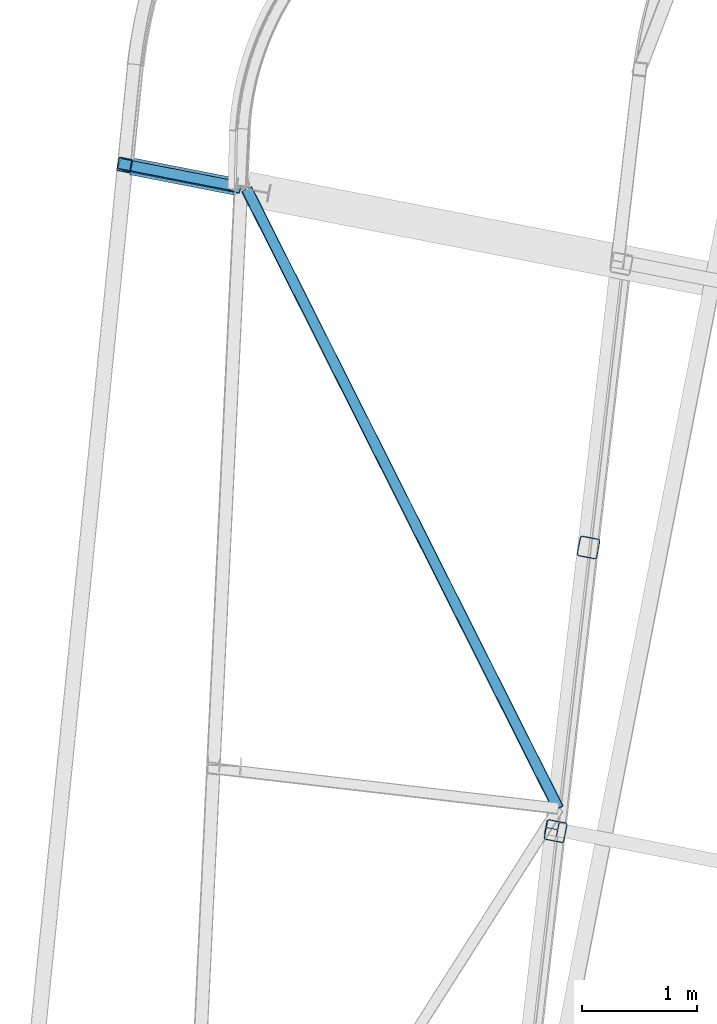
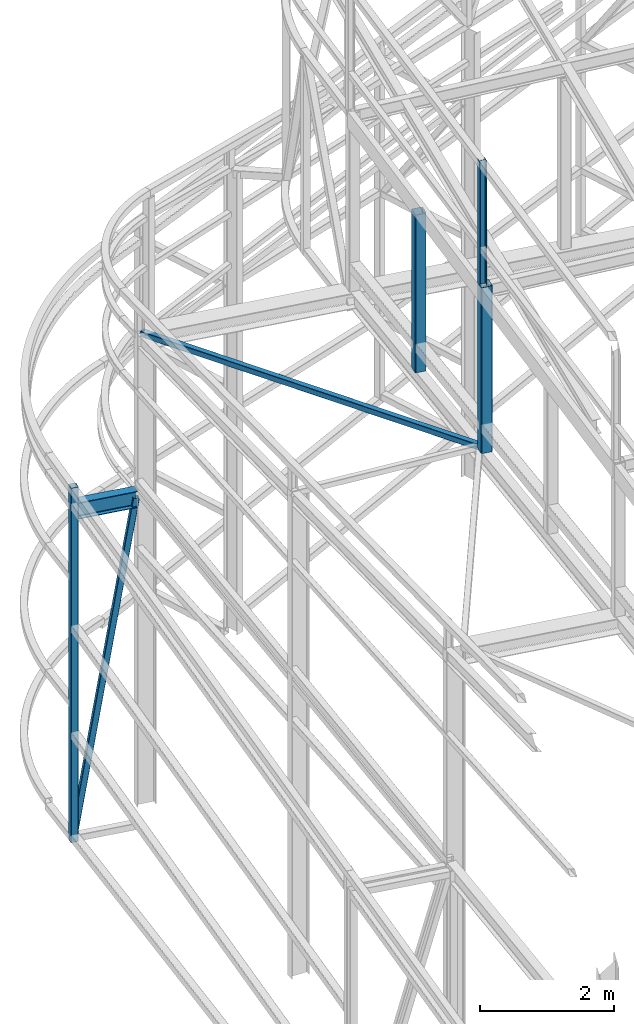
# One storey, part 76 of 215: 6 beams, 1 member, 7 elements without a shape of their own.
"""IFC2X3 building model written with IfcOpenShell, lengths in millimetres."""

from ifc_helpers import new_model, si_unit, frame, origin_with_axes, origin_2d_with_axis, place, context, subcontext, project, spatial, hollow_rectangle, i_section, extrude, clip, halfspace, material, type_object, element, aggregate, save


model = new_model("IFC2X3")

# Units and contexts
model_context = context("Model", 3, precision=1e-05, world=origin_with_axes())
body_context = subcontext(model_context, "Body", "Model", "MODEL_VIEW")
ifc_project = project(units=[si_unit("LENGTHUNIT", "METRE", prefix="MILLI"), si_unit("AREAUNIT", "SQUARE_METRE"), si_unit("VOLUMEUNIT", "CUBIC_METRE"), si_unit("MASSUNIT", "GRAM", prefix="KILO"), si_unit("TIMEUNIT", "SECOND"), si_unit("PLANEANGLEUNIT", "RADIAN"), si_unit("SOLIDANGLEUNIT", "STERADIAN"), si_unit("THERMODYNAMICTEMPERATUREUNIT", "DEGREE_CELSIUS"), si_unit("LUMINOUSINTENSITYUNIT", "LUMEN")], contexts=[model_context])

# Site, building, storey
site_placement = place(None, origin_with_axes())
site = spatial("IfcSite", under=ifc_project, at=site_placement, CompositionType="ELEMENT")
building_placement = place(site_placement, origin_with_axes())
building = spatial("IfcBuilding", under=site, at=building_placement, Name="Undefined", CompositionType="ELEMENT")
storey_placement = place(building_placement, origin_with_axes())
storey = spatial("IfcBuildingStorey", under=building, at=storey_placement, Name="Undefined", CompositionType="ELEMENT", Elevation=0.0)

# Assembly, beam
assembly_1_placement = place(storey_placement, origin_with_axes())
assembly_1 = element("IfcElementAssembly", 1, at=assembly_1_placement, inside=storey, Name="Steel Assembly", AssemblyPlace="NOTDEFINED", PredefinedType="RIGID_FRAME")
ifc_material = material(Name="STEEL/S275JR")
beam_type_1 = type_object("IfcBeamType", PredefinedType="NOTDEFINED")
beam_1_placement = place(assembly_1_placement, frame((38028.1385073162, 54568.5828169982, 6061.86710994504), z_axis=(-0.981474011903068, 0.191595312981076, 1.60599999965198e-06), x_axis=(-1.60500000047455e-06, 1.60999999464282e-07, -0.999999999998699)))
beam_1 = element("IfcBeam", 2, at=beam_1_placement, type_object=beam_type_1, material=ifc_material, Name="MONTANT", context=body_context, shape_type="SweptSolid", body=[
    extrude(hollow_rectangle(XDim=120.0, YDim=120.0, WallThickness=5.0, InnerFilletRadius=5.0, OuterFilletRadius=10.0, at=origin_2d_with_axis()), frame((6481.47571329646, -1.71563233624708e-19, -3.63798017959758e-12), z_axis=(-1.0, 0.0, 0.0), x_axis=(-6.93889390390723e-18, -1.0, -3.46944695195361e-18)), (0.0, 0.0, 1.0), 6481.5),
])
aggregate(assembly_1, [beam_1])

assembly_2_placement = place(storey_placement, origin_with_axes())
assembly_2 = element("IfcElementAssembly", 3, at=assembly_2_placement, inside=storey, Name="Steel Assembly", AssemblyPlace="NOTDEFINED", PredefinedType="RIGID_FRAME")
beam_type_2 = type_object("IfcBeamType", PredefinedType="NOTDEFINED")
beam_2_placement = place(assembly_2_placement, frame((39093.5616252917, 54357.4246603521, 8612.24870267854), z_axis=(0.893492208764054, 0.448243081881631, -0.0273827029927682), x_axis=(0.449041838079308, -0.892537652157635, 0.041688933007363)))
beam_2 = element("IfcBeam", 4, at=beam_2_placement, type_object=beam_type_2, material=ifc_material, context=body_context, shape_type="SweptSolid", body=[
    extrude(hollow_rectangle(XDim=100.0, YDim=100.0, WallThickness=5.0, InnerFilletRadius=5.0, OuterFilletRadius=10.0, at=origin_2d_with_axis()), frame((6055.13711101607, -1.81898940354586e-12, -1.15543873464118e-13), z_axis=(-1.0, 0.0, 0.0), x_axis=(-6.93889390390723e-18, -1.0, -3.46944695195361e-18)), (0.0, 0.0, 1.0), 6055.1),
])
aggregate(assembly_2, [beam_2])

# Assembly, member
assembly_3_placement = place(storey_placement, origin_with_axes())
assembly_3 = element("IfcElementAssembly", 5, at=assembly_3_placement, inside=storey, Name="Steel Assembly", AssemblyPlace="NOTDEFINED", PredefinedType="RIGID_FRAME")
member_type = type_object("IfcMemberType", PredefinedType="NOTDEFINED")
member_placement = place(assembly_3_placement, frame((38028.1361466811, 54568.5815651977, -337.5785075774), z_axis=(-0.942021209136917, 0.293672436042685, 0.162334660023595), x_axis=(0.160259745048045, -0.0312861390093792, 0.986578933295771)))
member = element("IfcMember", 6, at=member_placement, type_object=member_type, material=ifc_material, Name="POUTRE", context=body_context, shape_type="SweptSolid", body=[
    extrude(hollow_rectangle(XDim=100.0, YDim=100.0, WallThickness=5.0, InnerFilletRadius=5.0, OuterFilletRadius=10.0, at=origin_2d_with_axis()), frame((6049.70033473483, -7.23397938541027e-12, 3.63797880709171e-12), z_axis=(-1.0, 0.0, 0.0), x_axis=(-6.93889390390723e-18, -1.0, -3.46944695195361e-18)), (0.0, 0.0, 1.0), 6049.7),
])
aggregate(assembly_3, [member])

# Assembly, beam
assembly_4_placement = place(storey_placement, origin_with_axes())
assembly_4 = element("IfcElementAssembly", 7, at=assembly_4_placement, inside=storey, Name="Steel Assembly", AssemblyPlace="NOTDEFINED", PredefinedType="RIGID_FRAME")
beam_type_3 = type_object("IfcBeamType", PredefinedType="NOTDEFINED")
beam_3_placement = place(assembly_4_placement, frame((42077.040474429, 51230.6240304375, 11687.964098991), z_axis=(-0.981422412140383, 0.191859451027444, 0.0), x_axis=(0.0, 0.0, -1.0)))
beam_3 = element("IfcBeam", 8, at=beam_3_placement, type_object=beam_type_3, material=ifc_material, Name="MONTANT", context=body_context, shape_type="Clipping", body=[
    clip(extrude(hollow_rectangle(XDim=180.0, YDim=180.0, WallThickness=8.0, InnerFilletRadius=12.0, OuterFilletRadius=20.0, at=origin_2d_with_axis()), frame((2892.71413712809, 0.0, 0.0), z_axis=(-1.0, 0.0, 0.0), x_axis=(-6.93889390390723e-18, -1.0, -3.46944695195361e-18)), (0.0, 0.0, 1.0), 2892.7), halfspace(frame((2901.55690446262, -267.10006541614, 110.98515772813), z_axis=(-0.998757541180045, -0.0496840699304531, 0.00385579189483438), x_axis=(0.0, -0.0773735506072624, -0.997002173350904)), True)),
])
aggregate(assembly_4, [beam_3])

assembly_5_placement = place(storey_placement, origin_with_axes())
assembly_5 = element("IfcElementAssembly", 9, at=assembly_5_placement, inside=storey, Name="Steel Assembly", AssemblyPlace="NOTDEFINED", PredefinedType="RIGID_FRAME")
beam_4_placement = place(assembly_5_placement, frame((41789.6025156081, 48755.3321848554, 11966.9971244792), z_axis=(-0.981422412140383, 0.191859451027444, 0.0), x_axis=(0.0, 0.0, -1.0)))
beam_4 = element("IfcBeam", 10, at=beam_4_placement, type_object=beam_type_3, material=ifc_material, Name="MONTANT", context=body_context, shape_type="Clipping", body=[
    clip(clip(extrude(hollow_rectangle(XDim=180.0, YDim=180.0, WallThickness=8.0, InnerFilletRadius=12.0, OuterFilletRadius=20.0, at=origin_2d_with_axis()), frame((3042.53860213367, 0.0, 3.63797880709171e-12), z_axis=(-1.0, 0.0, 0.0), x_axis=(-6.93889390390723e-18, -1.0, -3.46944695195361e-18)), (0.0, 0.0, 1.0), 3039.8), halfspace(frame((3052.80799812582, -198.238645299731, 105.642087813081), z_axis=(-0.998757541180045, -0.0496840699304531, 0.00385579189483438), x_axis=(0.0, -0.0773735506072624, -0.997002173350904)), True)), halfspace(frame((3.02310036806193, -116.494875387238, 99.8437987933248), z_axis=(0.999997034433376, 0.00242814009745113, -0.000187776786755893), x_axis=(0.0, -0.0771033742924094, -0.997023103881111)), True)),
])
aggregate(assembly_5, [beam_4])

assembly_6_placement = place(storey_placement, origin_with_axes())
assembly_6 = element("IfcElementAssembly", 11, at=assembly_6_placement, inside=storey, Name="Steel Assembly", AssemblyPlace="NOTDEFINED", PredefinedType="RIGID_FRAME")
beam_type_4 = type_object("IfcBeamType", Name="HEA120", PredefinedType="NOTDEFINED")
beam_5_placement = place(assembly_6_placement, frame((41756.1385207334, 48777.7208070409, 14219.9969933385), z_axis=(0.981422409205525, -0.19185946604018, 1.89999991602007e-08), x_axis=(0.0, 0.0, -1.0)))
beam_5 = element("IfcBeam", 12, at=beam_5_placement, type_object=beam_type_4, material=ifc_material, ObjectType="HEA120", context=body_context, shape_type="SweptSolid", body=[
    extrude(i_section(OverallWidth=120.0, OverallDepth=114.0, WebThickness=5.0, FlangeThickness=8.0, FilletRadius=12.0, at=origin_2d_with_axis()), frame((2261.29950202445, -7.27595761792443e-12, -7.48201242900176e-21), z_axis=(-1.0, 0.0, 0.0), x_axis=(-6.93889390390723e-18, -1.0, -3.46944695195361e-18)), (0.0, 0.0, 1.0), 2261.3),
])
aggregate(assembly_6, [beam_5])

assembly_7_placement = place(storey_placement, origin_with_axes())
assembly_7 = element("IfcElementAssembly", 13, at=assembly_7_placement, inside=storey, Name="Steel Assembly", AssemblyPlace="NOTDEFINED", PredefinedType="RIGID_FRAME")
beam_type_5 = type_object("IfcBeamType", Name="IPE300", PredefinedType="NOTDEFINED")
beam_6_placement = place(assembly_7_placement, frame((38087.0222268778, 54557.0845946908, 5630.92839462914), z_axis=(0.0, 0.0, 1.0), x_axis=(0.981427016435528, -0.191835897085133, 0.0)))
beam_6 = element("IfcBeam", 14, at=beam_6_placement, type_object=beam_type_5, material=ifc_material, Name="POUTRE", ObjectType="IPE300", context=body_context, shape_type="SweptSolid", body=[
    extrude(i_section(OverallWidth=150.0, OverallDepth=300.0, WebThickness=7.099999905, FlangeThickness=10.69999981, FilletRadius=15.0, at=origin_2d_with_axis()), frame((927.828603169477, 0.0, 0.0), z_axis=(-1.0, 0.0, 0.0), x_axis=(-6.93889390390723e-18, -1.0, -3.46944695195361e-18)), (0.0, 0.0, 1.0), 927.8),
])
aggregate(assembly_7, [beam_6])

save(model, "model.ifc")
